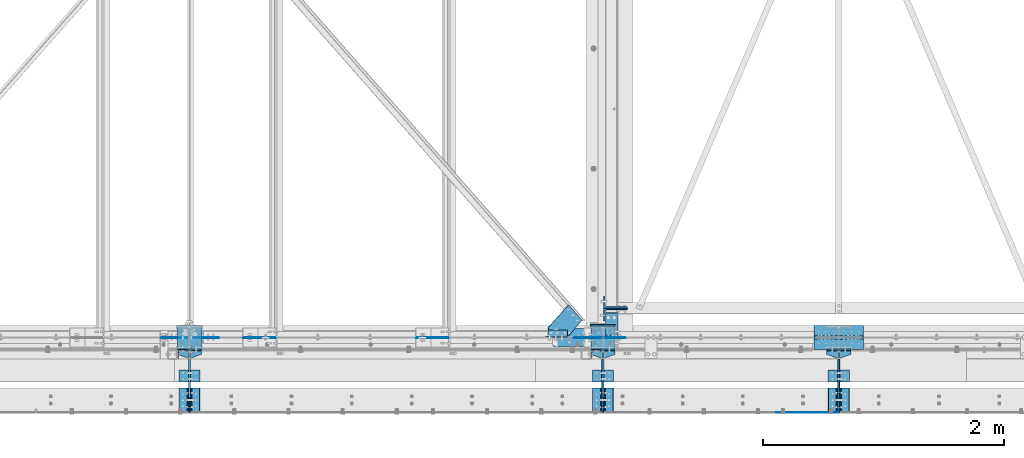
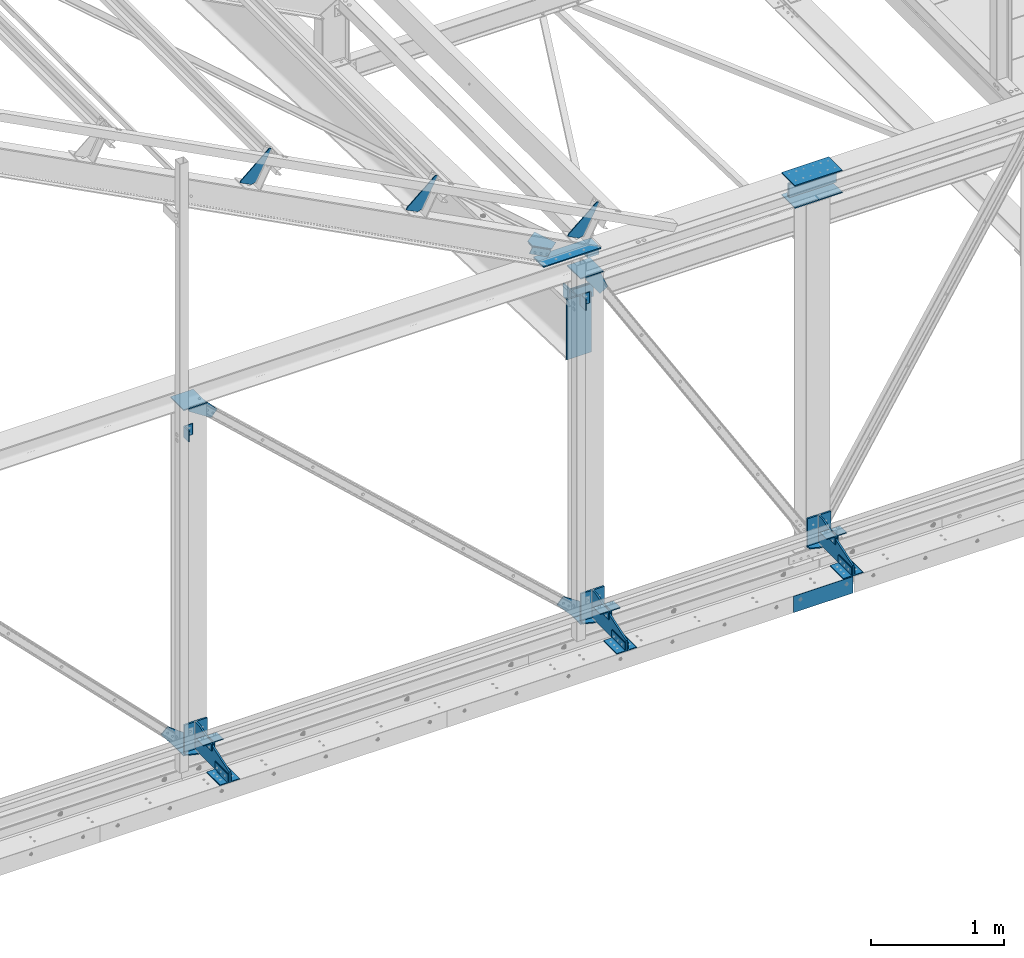
# One storey, part 84 of 496: 43 beams, 3 members, 34 elements without a shape of their own.
"""IFC2X3 building model written with IfcOpenShell, lengths in millimetres."""

from ifc_helpers import new_model, si_unit, frame, origin_with_axes, origin_2d_with_axis, place, context, subcontext, project, spatial, polyline, rectangle, l_section, outline, extrude, clip, halfspace, material, type_object, element, aggregate, save


model = new_model("IFC2X3")

# Units and contexts
model_context = context("Model", 3, precision=1e-05, world=origin_with_axes())
body_context = subcontext(model_context, "Body", "Model", "MODEL_VIEW")
ifc_project = project(units=[si_unit("LENGTHUNIT", "METRE", prefix="MILLI"), si_unit("AREAUNIT", "SQUARE_METRE"), si_unit("VOLUMEUNIT", "CUBIC_METRE"), si_unit("MASSUNIT", "GRAM", prefix="KILO"), si_unit("TIMEUNIT", "SECOND"), si_unit("PLANEANGLEUNIT", "RADIAN"), si_unit("SOLIDANGLEUNIT", "STERADIAN"), si_unit("THERMODYNAMICTEMPERATUREUNIT", "DEGREE_CELSIUS"), si_unit("LUMINOUSINTENSITYUNIT", "LUMEN")], contexts=[model_context])

# Site, building, storey
site_placement = place(None, origin_with_axes())
site = spatial("IfcSite", under=ifc_project, at=site_placement, CompositionType="ELEMENT")
building_placement = place(site_placement, origin_with_axes())
building = spatial("IfcBuilding", under=site, at=building_placement, Name="Undefined", CompositionType="ELEMENT")
storey_placement = place(building_placement, origin_with_axes())
storey = spatial("IfcBuildingStorey", under=building, at=storey_placement, Name="Undefined", CompositionType="ELEMENT", Elevation=0.0)

# Assembly, beam
assembly_1_placement = place(storey_placement, origin_with_axes())
assembly_1 = element("IfcElementAssembly", 1, at=assembly_1_placement, inside=storey, Name="MONTANT", AssemblyPlace="NOTDEFINED", PredefinedType="NOTDEFINED")
ifc_material = material(Name="Undefined/S235-E24")
beam_type_1 = type_object("IfcBeamType", PredefinedType="NOTDEFINED")
beam_1_placement = place(assembly_1_placement, frame((16014.9968916014, 0.0, 5200.00069263517), z_axis=(0.0, -1.0, 0.0), x_axis=(1.0, 0.0, 0.0)))
beam_1 = element("IfcBeam", 2, at=beam_1_placement, type_object=beam_type_1, material=ifc_material, context=body_context, shape_type="SweptSolid", body=[
    extrude(outline(polyline([(0.0, 0.0), (76.7515563964844, -3.31884703335521e-11), (96.7515747071295, 19.9999999994966), (96.7516021728516, 100.0), (-82.7663345336914, 231.440887451172), (-139.650405883789, 175.189651489258), (0.0, 0.0)])), frame((0.0, 0.0, -4.0), z_axis=(0.0, 0.0, 1.0), x_axis=(1.0, 0.0, 0.0)), (0.0, 0.0, 1.0), 8.0),
])

assembly_2_placement = place(storey_placement, origin_with_axes())
assembly_2 = element("IfcElementAssembly", 3, at=assembly_2_placement, inside=storey, Name="SUPPORT", AssemblyPlace="NOTDEFINED", PredefinedType="NOTDEFINED")
beam_type_2 = type_object("IfcBeamType", PredefinedType="NOTDEFINED")
beam_2_placement = place(assembly_2_placement, frame((20989.9999820849, -622.0, 5154.99824538435), z_axis=(0.0, 0.0, 1.0), x_axis=(1.0, 0.0, 0.0)))
beam_2 = element("IfcBeam", 4, at=beam_2_placement, type_object=beam_type_2, material=ifc_material, Name="SUPPORT", context=body_context, shape_type="SweptSolid", body=[
    extrude(rectangle(XDim=4.0, YDim=150.0, at=origin_2d_with_axis()), frame((515.000011943383, 0.0, 0.0), z_axis=(-1.0, 0.0, 0.0), x_axis=(0.0, -1.0, 0.0)), (0.0, 0.0, 1.0), 515.0),
])
aggregate(assembly_2, [beam_2])

assembly_3_placement = place(storey_placement, origin_with_axes())
assembly_3 = element("IfcElementAssembly", 5, at=assembly_3_placement, inside=storey, Name="MONTANT", AssemblyPlace="NOTDEFINED", PredefinedType="NOTDEFINED")
beam_type_3 = type_object("IfcBeamType", PredefinedType="NOTDEFINED")
beam_3_placement = place(assembly_3_placement, frame((21304.9998196885, 0.0, 8354.99960117714), z_axis=(0.0, 1.0, 0.0), x_axis=(0.999999999995014, 0.0, -3.15800000114453e-06)))
beam_3 = element("IfcBeam", 6, at=beam_3_placement, type_object=beam_type_3, material=ifc_material, context=body_context, shape_type="SweptSolid", body=[
    extrude(rectangle(XDim=10.0, YDim=200.0, at=origin_2d_with_axis()), frame((410.0, 0.0, 0.0), z_axis=(-1.0, 0.0, 0.0), x_axis=(0.0, -1.0, 0.0)), (0.0, 0.0, 1.0), 410.0),
])
aggregate(assembly_3, [beam_3])

assembly_4_placement = place(storey_placement, origin_with_axes())
assembly_4 = element("IfcElementAssembly", 7, at=assembly_4_placement, inside=storey, AssemblyPlace="NOTDEFINED", PredefinedType="NOTDEFINED")
beam_4_placement = place(assembly_4_placement, frame((21304.9998196885, 0.0, 8555.00039882286), z_axis=(0.0, 1.0, 0.0), x_axis=(0.999999999995014, 0.0, 3.15800000114453e-06)))
beam_4 = element("IfcBeam", 8, at=beam_4_placement, type_object=beam_type_3, material=ifc_material, context=body_context, shape_type="SweptSolid", body=[
    extrude(rectangle(XDim=10.0, YDim=200.0, at=origin_2d_with_axis()), frame((410.0, 0.0, 0.0), z_axis=(-1.0, 0.0, 0.0), x_axis=(0.0, -1.0, 0.0)), (0.0, 0.0, 1.0), 410.0),
])
aggregate(assembly_4, [beam_4])

# Assembly, beams
assembly_5_placement = place(storey_placement, origin_with_axes())
assembly_5 = element("IfcElementAssembly", 9, at=assembly_5_placement, inside=storey, Name="MONTANT", AssemblyPlace="NOTDEFINED", PredefinedType="NOTDEFINED")
beam_5_placement = place(assembly_5_placement, frame((19449.9982817512, 0.0, 8354.99930736483), z_axis=(0.0, 1.0, 0.0), x_axis=(1.0, 0.0, 0.0)))
beam_5 = element("IfcBeam", 10, at=beam_5_placement, type_object=beam_type_3, material=ifc_material, context=body_context, shape_type="SweptSolid", body=[
    extrude(rectangle(XDim=10.0, YDim=200.0, at=origin_2d_with_axis()), frame((200.003108907451, 1.3235095531086e-21, 0.0), z_axis=(-1.0, 0.0, 0.0), x_axis=(0.0, -1.0, 0.0)), (0.0, 0.0, 1.0), 200.0),
])
beam_6_placement = place(assembly_5_placement, frame((19449.9982812412, 0.0, 5195.00069263517), z_axis=(0.0, 1.0, 0.0), x_axis=(1.0, 0.0, 0.0)))
beam_6 = element("IfcBeam", 11, at=beam_6_placement, type_object=beam_type_3, material=ifc_material, context=body_context, shape_type="SweptSolid", body=[
    extrude(rectangle(XDim=10.0, YDim=200.0, at=origin_2d_with_axis()), frame((200.003108907451, 1.3235095531086e-21, 0.0), z_axis=(-1.0, 0.0, 0.0), x_axis=(0.0, -1.0, 0.0)), (0.0, 0.0, 1.0), 200.0),
])

# Beam
beam_7_placement = place(assembly_1_placement, frame((16014.9968918183, 0.0, 8354.99930736483), z_axis=(0.0, 1.0, 0.0), x_axis=(1.0, 0.0, 0.0)))
beam_7 = element("IfcBeam", 12, at=beam_7_placement, type_object=beam_type_3, material=ifc_material, context=body_context, shape_type="SweptSolid", body=[
    extrude(rectangle(XDim=10.0, YDim=200.0, at=origin_2d_with_axis()), frame((200.003108907451, 1.3235095531086e-21, 0.0), z_axis=(-1.0, 0.0, 0.0), x_axis=(0.0, -1.0, 0.0)), (0.0, 0.0, 1.0), 200.0),
])

beam_8_placement = place(assembly_1_placement, frame((16014.9968913083, 0.0, 5195.00069263517), z_axis=(0.0, 1.0, 0.0), x_axis=(1.0, 0.0, 0.0)))
beam_8 = element("IfcBeam", 13, at=beam_8_placement, type_object=beam_type_3, material=ifc_material, context=body_context, shape_type="SweptSolid", body=[
    extrude(rectangle(XDim=10.0, YDim=200.0, at=origin_2d_with_axis()), frame((200.003108907451, 1.3235095531086e-21, 0.0), z_axis=(-1.0, 0.0, 0.0), x_axis=(0.0, -1.0, 0.0)), (0.0, 0.0, 1.0), 200.0),
])

# Assembly, beam
assembly_6_placement = place(storey_placement, origin_with_axes())
assembly_6 = element("IfcElementAssembly", 14, at=assembly_6_placement, inside=storey, AssemblyPlace="NOTDEFINED", PredefinedType="NOTDEFINED")
beam_type_4 = type_object("IfcBeamType", PredefinedType="NOTDEFINED")
beam_9_placement = place(assembly_6_placement, frame((21557.4921660686, -270.0, 5409.99824538435), z_axis=(0.0, 0.0, -1.0), x_axis=(0.0, -1.0, 0.0)))
beam_9 = element("IfcBeam", 15, at=beam_9_placement, type_object=beam_type_4, material=ifc_material, context=body_context, shape_type="SweptSolid", body=[
    extrude(l_section(Depth=80.0, Width=80.0, Thickness=8.0, FilletRadius=10.0, EdgeRadius=5.0, at=origin_2d_with_axis()), frame((100.000000000021, 5.72981662116945e-11, -4.09272615797818e-12), z_axis=(-1.0, 0.0, 0.0), x_axis=(0.0, -1.0, 0.0)), (0.0, 0.0, 1.0), 100.0),
])
aggregate(assembly_6, [beam_9])

assembly_7_placement = place(storey_placement, origin_with_axes())
assembly_7 = element("IfcElementAssembly", 16, at=assembly_7_placement, inside=storey, AssemblyPlace="NOTDEFINED", PredefinedType="NOTDEFINED")
beam_10_placement = place(assembly_7_placement, frame((21462.4999984401, -370.0, 5409.99824538435), z_axis=(0.0, 0.0, -1.0), x_axis=(0.0, 1.0, 0.0)))
beam_10 = element("IfcBeam", 17, at=beam_10_placement, type_object=beam_type_4, material=ifc_material, context=body_context, shape_type="SweptSolid", body=[
    extrude(l_section(Depth=80.0, Width=80.0, Thickness=8.0, FilletRadius=10.0, EdgeRadius=5.0, at=origin_2d_with_axis()), frame((100.000000000021, 5.72981662116945e-11, -4.09272615797818e-12), z_axis=(-1.0, 0.0, 0.0), x_axis=(0.0, -1.0, 0.0)), (0.0, 0.0, 1.0), 100.0),
])
aggregate(assembly_7, [beam_10])

assembly_8_placement = place(storey_placement, origin_with_axes())
assembly_8 = element("IfcElementAssembly", 18, at=assembly_8_placement, inside=storey, AssemblyPlace="NOTDEFINED", PredefinedType="NOTDEFINED")
beam_11_placement = place(assembly_8_placement, frame((19597.4921676285, -270.0, 5409.99824538435), z_axis=(0.0, 0.0, -1.0), x_axis=(0.0, -1.0, 0.0)))
beam_11 = element("IfcBeam", 19, at=beam_11_placement, type_object=beam_type_4, material=ifc_material, context=body_context, shape_type="SweptSolid", body=[
    extrude(l_section(Depth=80.0, Width=80.0, Thickness=8.0, FilletRadius=10.0, EdgeRadius=5.0, at=origin_2d_with_axis()), frame((100.000000000021, 5.72981662116945e-11, -4.09272615797818e-12), z_axis=(-1.0, 0.0, 0.0), x_axis=(0.0, -1.0, 0.0)), (0.0, 0.0, 1.0), 100.0),
])
aggregate(assembly_8, [beam_11])

assembly_9_placement = place(storey_placement, origin_with_axes())
assembly_9 = element("IfcElementAssembly", 20, at=assembly_9_placement, inside=storey, AssemblyPlace="NOTDEFINED", PredefinedType="NOTDEFINED")
beam_12_placement = place(assembly_9_placement, frame((19502.5, -370.0, 5409.99824538435), z_axis=(0.0, 0.0, -1.0), x_axis=(0.0, 1.0, 0.0)))
beam_12 = element("IfcBeam", 21, at=beam_12_placement, type_object=beam_type_4, material=ifc_material, context=body_context, shape_type="SweptSolid", body=[
    extrude(l_section(Depth=80.0, Width=80.0, Thickness=8.0, FilletRadius=10.0, EdgeRadius=5.0, at=origin_2d_with_axis()), frame((100.000000000021, 5.72981662116945e-11, -4.09272615797818e-12), z_axis=(-1.0, 0.0, 0.0), x_axis=(0.0, -1.0, 0.0)), (0.0, 0.0, 1.0), 100.0),
])
aggregate(assembly_9, [beam_12])

assembly_10_placement = place(storey_placement, origin_with_axes())
assembly_10 = element("IfcElementAssembly", 22, at=assembly_10_placement, inside=storey, AssemblyPlace="NOTDEFINED", PredefinedType="NOTDEFINED")
beam_13_placement = place(assembly_10_placement, frame((16162.490751722, -270.0, 5409.99824538435), z_axis=(0.0, 0.0, -1.0), x_axis=(0.0, -1.0, 0.0)))
beam_13 = element("IfcBeam", 23, at=beam_13_placement, type_object=beam_type_4, material=ifc_material, context=body_context, shape_type="SweptSolid", body=[
    extrude(l_section(Depth=80.0, Width=80.0, Thickness=8.0, FilletRadius=10.0, EdgeRadius=5.0, at=origin_2d_with_axis()), frame((100.000000000021, 5.72981662116945e-11, -4.09272615797818e-12), z_axis=(-1.0, 0.0, 0.0), x_axis=(0.0, -1.0, 0.0)), (0.0, 0.0, 1.0), 100.0),
])
aggregate(assembly_10, [beam_13])

assembly_11_placement = place(storey_placement, origin_with_axes())
assembly_11 = element("IfcElementAssembly", 24, at=assembly_11_placement, inside=storey, AssemblyPlace="NOTDEFINED", PredefinedType="NOTDEFINED")
beam_14_placement = place(assembly_11_placement, frame((16067.4985840935, -370.0, 5409.99824538435), z_axis=(0.0, 0.0, -1.0), x_axis=(0.0, 1.0, 0.0)))
beam_14 = element("IfcBeam", 25, at=beam_14_placement, type_object=beam_type_4, material=ifc_material, context=body_context, shape_type="SweptSolid", body=[
    extrude(l_section(Depth=80.0, Width=80.0, Thickness=8.0, FilletRadius=10.0, EdgeRadius=5.0, at=origin_2d_with_axis()), frame((100.000000000021, 5.72981662116945e-11, -4.09272615797818e-12), z_axis=(-1.0, 0.0, 0.0), x_axis=(0.0, -1.0, 0.0)), (0.0, 0.0, 1.0), 100.0),
])
aggregate(assembly_11, [beam_14])

assembly_12_placement = place(storey_placement, origin_with_axes())
assembly_12 = element("IfcElementAssembly", 26, at=assembly_12_placement, inside=storey, AssemblyPlace="NOTDEFINED", PredefinedType="NOTDEFINED")
beam_15_placement = place(assembly_12_placement, frame((21557.4921660686, -620.0, 5269.99824538435), z_axis=(0.0, 0.0, 1.0), x_axis=(0.0, 1.0, 0.0)))
beam_15 = element("IfcBeam", 27, at=beam_15_placement, type_object=beam_type_4, material=ifc_material, context=body_context, shape_type="SweptSolid", body=[
    extrude(l_section(Depth=80.0, Width=80.0, Thickness=8.0, FilletRadius=10.0, EdgeRadius=5.0, at=origin_2d_with_axis()), frame((200.0, 0.0, 0.0), z_axis=(-1.0, 0.0, 0.0), x_axis=(0.0, -1.0, 0.0)), (0.0, 0.0, 1.0), 200.0),
])
aggregate(assembly_12, [beam_15])

assembly_13_placement = place(storey_placement, origin_with_axes())
assembly_13 = element("IfcElementAssembly", 28, at=assembly_13_placement, inside=storey, AssemblyPlace="NOTDEFINED", PredefinedType="NOTDEFINED")
beam_16_placement = place(assembly_13_placement, frame((21462.4999984401, -420.0, 5269.99824538435), z_axis=(0.0, 0.0, 1.0), x_axis=(0.0, -1.0, 0.0)))
beam_16 = element("IfcBeam", 29, at=beam_16_placement, type_object=beam_type_4, material=ifc_material, context=body_context, shape_type="SweptSolid", body=[
    extrude(l_section(Depth=80.0, Width=80.0, Thickness=8.0, FilletRadius=10.0, EdgeRadius=5.0, at=origin_2d_with_axis()), frame((200.0, 0.0, 0.0), z_axis=(-1.0, 0.0, 0.0), x_axis=(0.0, -1.0, 0.0)), (0.0, 0.0, 1.0), 200.0),
])
aggregate(assembly_13, [beam_16])

assembly_14_placement = place(storey_placement, origin_with_axes())
assembly_14 = element("IfcElementAssembly", 30, at=assembly_14_placement, inside=storey, AssemblyPlace="NOTDEFINED", PredefinedType="NOTDEFINED")
beam_17_placement = place(assembly_14_placement, frame((19597.4921676285, -620.0, 5269.99824538435), z_axis=(0.0, 0.0, 1.0), x_axis=(0.0, 1.0, 0.0)))
beam_17 = element("IfcBeam", 31, at=beam_17_placement, type_object=beam_type_4, material=ifc_material, context=body_context, shape_type="SweptSolid", body=[
    extrude(l_section(Depth=80.0, Width=80.0, Thickness=8.0, FilletRadius=10.0, EdgeRadius=5.0, at=origin_2d_with_axis()), frame((200.0, 0.0, 0.0), z_axis=(-1.0, 0.0, 0.0), x_axis=(0.0, -1.0, 0.0)), (0.0, 0.0, 1.0), 200.0),
])
aggregate(assembly_14, [beam_17])

assembly_15_placement = place(storey_placement, origin_with_axes())
assembly_15 = element("IfcElementAssembly", 32, at=assembly_15_placement, inside=storey, AssemblyPlace="NOTDEFINED", PredefinedType="NOTDEFINED")
beam_18_placement = place(assembly_15_placement, frame((19502.5, -420.0, 5269.99824538435), z_axis=(0.0, 0.0, 1.0), x_axis=(0.0, -1.0, 0.0)))
beam_18 = element("IfcBeam", 33, at=beam_18_placement, type_object=beam_type_4, material=ifc_material, context=body_context, shape_type="SweptSolid", body=[
    extrude(l_section(Depth=80.0, Width=80.0, Thickness=8.0, FilletRadius=10.0, EdgeRadius=5.0, at=origin_2d_with_axis()), frame((200.0, 0.0, 0.0), z_axis=(-1.0, 0.0, 0.0), x_axis=(0.0, -1.0, 0.0)), (0.0, 0.0, 1.0), 200.0),
])
aggregate(assembly_15, [beam_18])

assembly_16_placement = place(storey_placement, origin_with_axes())
assembly_16 = element("IfcElementAssembly", 34, at=assembly_16_placement, inside=storey, AssemblyPlace="NOTDEFINED", PredefinedType="NOTDEFINED")
beam_19_placement = place(assembly_16_placement, frame((16162.490751722, -620.0, 5269.99824538435), z_axis=(0.0, 0.0, 1.0), x_axis=(0.0, 1.0, 0.0)))
beam_19 = element("IfcBeam", 35, at=beam_19_placement, type_object=beam_type_4, material=ifc_material, context=body_context, shape_type="SweptSolid", body=[
    extrude(l_section(Depth=80.0, Width=80.0, Thickness=8.0, FilletRadius=10.0, EdgeRadius=5.0, at=origin_2d_with_axis()), frame((200.0, 0.0, 0.0), z_axis=(-1.0, 0.0, 0.0), x_axis=(0.0, -1.0, 0.0)), (0.0, 0.0, 1.0), 200.0),
])
aggregate(assembly_16, [beam_19])

assembly_17_placement = place(storey_placement, origin_with_axes())
assembly_17 = element("IfcElementAssembly", 36, at=assembly_17_placement, inside=storey, AssemblyPlace="NOTDEFINED", PredefinedType="NOTDEFINED")
beam_20_placement = place(assembly_17_placement, frame((16067.4985840935, -420.0, 5269.99824538435), z_axis=(0.0, 0.0, 1.0), x_axis=(0.0, -1.0, 0.0)))
beam_20 = element("IfcBeam", 37, at=beam_20_placement, type_object=beam_type_4, material=ifc_material, context=body_context, shape_type="SweptSolid", body=[
    extrude(l_section(Depth=80.0, Width=80.0, Thickness=8.0, FilletRadius=10.0, EdgeRadius=5.0, at=origin_2d_with_axis()), frame((200.0, 0.0, 0.0), z_axis=(-1.0, 0.0, 0.0), x_axis=(0.0, -1.0, 0.0)), (0.0, 0.0, 1.0), 200.0),
])
aggregate(assembly_17, [beam_20])

assembly_18_placement = place(storey_placement, origin_with_axes())
assembly_18 = element("IfcElementAssembly", 38, at=assembly_18_placement, inside=storey, AssemblyPlace="NOTDEFINED", PredefinedType="NOTDEFINED")
beam_21_placement = place(assembly_18_placement, frame((19489.9999999948, -134.999999998163, 8210.00066229852), z_axis=(1.0, 0.0, 0.0), x_axis=(0.0, 0.0, -1.0)))
beam_21 = element("IfcBeam", 39, at=beam_21_placement, type_object=beam_type_4, material=ifc_material, context=body_context, shape_type="SweptSolid", body=[
    extrude(l_section(Depth=80.0, Width=80.0, Thickness=8.0, FilletRadius=10.0, EdgeRadius=5.0, at=origin_2d_with_axis()), frame((100.000000000021, 5.72981662116945e-11, -4.09272615797818e-12), z_axis=(-1.0, 0.0, 0.0), x_axis=(0.0, -1.0, 0.0)), (0.0, 0.0, 1.0), 100.0),
])
aggregate(assembly_18, [beam_21])

assembly_19_placement = place(storey_placement, origin_with_axes())
assembly_19 = element("IfcElementAssembly", 40, at=assembly_19_placement, inside=storey, AssemblyPlace="NOTDEFINED", PredefinedType="NOTDEFINED")
beam_22_placement = place(assembly_19_placement, frame((16054.9998811591, -135.000000001492, 8210.00066228986), z_axis=(1.0, 0.0, 0.0), x_axis=(0.0, 0.0, -1.0)))
beam_22 = element("IfcBeam", 41, at=beam_22_placement, type_object=beam_type_4, material=ifc_material, context=body_context, shape_type="SweptSolid", body=[
    extrude(l_section(Depth=80.0, Width=80.0, Thickness=8.0, FilletRadius=10.0, EdgeRadius=5.0, at=origin_2d_with_axis()), frame((100.000000000021, 5.72981662116945e-11, -4.09272615797818e-12), z_axis=(-1.0, 0.0, 0.0), x_axis=(0.0, -1.0, 0.0)), (0.0, 0.0, 1.0), 100.0),
])
aggregate(assembly_19, [beam_22])

assembly_20_placement = place(storey_placement, origin_with_axes())
assembly_20 = element("IfcElementAssembly", 42, at=assembly_20_placement, inside=storey, Name="CONSOLE", AssemblyPlace="NOTDEFINED", PredefinedType="NOTDEFINED")
beam_type_5 = type_object("IfcBeamType", PredefinedType="NOTDEFINED")
beam_23_placement = place(assembly_20_placement, frame((16014.9985840935, -110.0, 5224.99824534403), z_axis=(0.0, 0.0, 1.0), x_axis=(0.0, -1.0, 0.0)))
beam_23 = element("IfcBeam", 43, at=beam_23_placement, type_object=beam_type_5, material=ifc_material, context=body_context, shape_type="SweptSolid", body=[
    extrude(outline(polyline([(0.0, 0.0), (30.0, 0.0), (60.0, 82.5), (60.0, 117.5), (30.0, 200.0), (0.0, 200.0), (0.0, 0.0)])), frame((0.0, 0.0, -5.0), z_axis=(0.0, 0.0, 1.0), x_axis=(1.0, 0.0, 0.0)), (0.0, 0.0, 1.0), 10.0),
])

assembly_21_placement = place(storey_placement, origin_with_axes())
assembly_21 = element("IfcElementAssembly", 44, at=assembly_21_placement, inside=storey, Name="CONSOLE", AssemblyPlace="NOTDEFINED", PredefinedType="NOTDEFINED")
beam_24_placement = place(assembly_21_placement, frame((19450.0, -110.0, 5224.99824534403), z_axis=(0.0, 0.0, 1.0), x_axis=(0.0, -1.0, 0.0)))
beam_24 = element("IfcBeam", 45, at=beam_24_placement, type_object=beam_type_5, material=ifc_material, context=body_context, shape_type="SweptSolid", body=[
    extrude(outline(polyline([(0.0, 0.0), (30.0, 0.0), (60.0, 82.5), (60.0, 117.5), (30.0, 200.0), (0.0, 200.0), (0.0, 0.0)])), frame((0.0, 0.0, -5.0), z_axis=(0.0, 0.0, 1.0), x_axis=(1.0, 0.0, 0.0)), (0.0, 0.0, 1.0), 10.0),
])

# Assembly, beams
assembly_22_placement = place(storey_placement, origin_with_axes())
assembly_22 = element("IfcElementAssembly", 46, at=assembly_22_placement, inside=storey, Name="CONSOLE", AssemblyPlace="NOTDEFINED", PredefinedType="NOTDEFINED")
beam_25_placement = place(assembly_22_placement, frame((21409.9999984401, -110.0, 5224.99824534403), z_axis=(0.0, 0.0, 1.0), x_axis=(0.0, -1.0, 0.0)))
beam_25 = element("IfcBeam", 47, at=beam_25_placement, type_object=beam_type_5, material=ifc_material, context=body_context, shape_type="SweptSolid", body=[
    extrude(outline(polyline([(0.0, 0.0), (30.0, 0.0), (60.0, 82.5), (60.0, 117.5), (30.0, 200.0), (0.0, 200.0), (0.0, 0.0)])), frame((0.0, 0.0, -5.0), z_axis=(0.0, 0.0, 1.0), x_axis=(1.0, 0.0, 0.0)), (0.0, 0.0, 1.0), 10.0),
])
beam_type_6 = type_object("IfcBeamType", PredefinedType="NOTDEFINED")
beam_26_placement = place(assembly_22_placement, frame((21509.9999984401, -102.5, 5479.99824538435), z_axis=(1.0, 0.0, 0.0), x_axis=(0.0, 0.0, -1.0)))
beam_26 = element("IfcBeam", 48, at=beam_26_placement, type_object=beam_type_6, material=ifc_material, context=body_context, shape_type="SweptSolid", body=[
    extrude(rectangle(XDim=15.0, YDim=200.0, at=origin_2d_with_axis()), frame((265.000000057562, 0.0, 0.0), z_axis=(-1.0, 0.0, 0.0), x_axis=(0.0, -1.0, 0.0)), (0.0, 0.0, 1.0), 265.0),
])

# Beam
beam_27_placement = place(assembly_21_placement, frame((19550.0, -102.5, 5479.99824538435), z_axis=(1.0, 0.0, 0.0), x_axis=(0.0, 0.0, -1.0)))
beam_27 = element("IfcBeam", 49, at=beam_27_placement, type_object=beam_type_6, material=ifc_material, context=body_context, shape_type="SweptSolid", body=[
    extrude(rectangle(XDim=15.0, YDim=200.0, at=origin_2d_with_axis()), frame((265.000000057562, 0.0, 0.0), z_axis=(-1.0, 0.0, 0.0), x_axis=(0.0, -1.0, 0.0)), (0.0, 0.0, 1.0), 265.0),
])

beam_28_placement = place(assembly_20_placement, frame((16114.9985840935, -102.5, 5479.99824538435), z_axis=(1.0, 0.0, 0.0), x_axis=(0.0, 0.0, -1.0)))
beam_28 = element("IfcBeam", 50, at=beam_28_placement, type_object=beam_type_6, material=ifc_material, context=body_context, shape_type="SweptSolid", body=[
    extrude(rectangle(XDim=15.0, YDim=200.0, at=origin_2d_with_axis()), frame((265.000000057562, 0.0, 0.0), z_axis=(-1.0, 0.0, 0.0), x_axis=(0.0, -1.0, 0.0)), (0.0, 0.0, 1.0), 265.0),
])

beam_type_7 = type_object("IfcBeamType", PredefinedType="NOTDEFINED")
beam_29_placement = place(assembly_22_placement, frame((21509.9999984401, -620.0, 5229.99824538435), z_axis=(-1.0, 0.0, 0.0), x_axis=(0.0, 0.0, 1.0)))
beam_29 = element("IfcBeam", 51, at=beam_29_placement, type_object=beam_type_7, material=ifc_material, Name="CONSOLE", context=body_context, shape_type="SweptSolid", body=[
    extrude(outline(polyline([(0.0, 0.0), (100.0, 0.0), (250.0, 450.0), (250.0, 510.0), (19.9999999424381, 510.0), (-5.53045894918671e-08, 490.0), (0.0, 0.0)])), frame((0.0, 0.0, -7.5), z_axis=(0.0, 0.0, 1.0), x_axis=(1.0, 0.0, 0.0)), (0.0, 0.0, 1.0), 15.0),
])

aggregate(assembly_22, [beam_25, beam_26, beam_29])

beam_30_placement = place(assembly_21_placement, frame((19550.0, -620.0, 5229.99824538435), z_axis=(-1.0, 0.0, 0.0), x_axis=(0.0, 0.0, 1.0)))
beam_30 = element("IfcBeam", 52, at=beam_30_placement, type_object=beam_type_7, material=ifc_material, Name="CONSOLE", context=body_context, shape_type="SweptSolid", body=[
    extrude(outline(polyline([(0.0, 0.0), (100.0, 0.0), (250.0, 450.0), (250.0, 510.0), (19.9999999424381, 510.0), (-5.53045894918671e-08, 490.0), (0.0, 0.0)])), frame((0.0, 0.0, -7.5), z_axis=(0.0, 0.0, 1.0), x_axis=(1.0, 0.0, 0.0)), (0.0, 0.0, 1.0), 15.0),
])

aggregate(assembly_21, [beam_24, beam_27, beam_30])

beam_31_placement = place(assembly_20_placement, frame((16114.9985840935, -620.0, 5229.99824538435), z_axis=(-1.0, 0.0, 0.0), x_axis=(0.0, 0.0, 1.0)))
beam_31 = element("IfcBeam", 53, at=beam_31_placement, type_object=beam_type_7, material=ifc_material, Name="CONSOLE", context=body_context, shape_type="SweptSolid", body=[
    extrude(outline(polyline([(0.0, 0.0), (100.0, 0.0), (250.0, 450.0), (250.0, 510.0), (19.9999999424381, 510.0), (-5.53045894918671e-08, 490.0), (0.0, 0.0)])), frame((0.0, 0.0, -7.5), z_axis=(0.0, 0.0, 1.0), x_axis=(1.0, 0.0, 0.0)), (0.0, 0.0, 1.0), 15.0),
])

aggregate(assembly_20, [beam_23, beam_28, beam_31])

# Assembly, member
assembly_23_placement = place(storey_placement, origin_with_axes())
assembly_23 = element("IfcElementAssembly", 54, at=assembly_23_placement, inside=storey, AssemblyPlace="NOTDEFINED", PredefinedType="NOTDEFINED")
member_type_1 = type_object("IfcMemberType", PredefinedType="NOTDEFINED")
member_1_placement = place(assembly_23_placement, frame((19240.9060810752, 33.499997216567, 8598.41231176399), z_axis=(0.0, 1.0, 0.0), x_axis=(-0.886081824994261, -1.3000000762986e-08, 0.46352885499701)))
member_1 = element("IfcMember", 55, at=member_1_placement, type_object=member_type_1, material=ifc_material, context=body_context, shape_type="SweptSolid", body=[
    extrude(l_section(Depth=60.0, Width=60.0, Thickness=6.0, FilletRadius=8.0, EdgeRadius=4.0, at=origin_2d_with_axis()), frame((180.0, 0.0, 0.0), z_axis=(-1.0, 0.0, 0.0), x_axis=(0.0, -1.0, 0.0)), (0.0, 0.0, 1.0), 180.0),
])
aggregate(assembly_23, [member_1])

# Assembly, beam
assembly_24_placement = place(storey_placement, origin_with_axes())
assembly_24 = element("IfcElementAssembly", 56, at=assembly_24_placement, inside=storey, Name="SHED", AssemblyPlace="NOTDEFINED", PredefinedType="NOTDEFINED")
beam_type_8 = type_object("IfcBeamType", PredefinedType="NOTDEFINED")
beam_32_placement = place(assembly_24_placement, frame((19667.0878027865, 0.0, 8923.94974997789), z_axis=(0.0, -1.0, 0.0), x_axis=(-0.886081824994261, -1.3000000762986e-08, 0.46352885499701)))
beam_32 = element("IfcBeam", 57, at=beam_32_placement, type_object=beam_type_8, material=ifc_material, context=body_context, shape_type="SweptSolid", body=[
    extrude(outline(polyline([(0.0, 0.0), (20.0, 0.0), (140.000030519084, 299.999999999567), (140.000030519153, 319.999999999545), (30.0000147075953, 319.999999999634), (0.0, 290.0), (0.0, 0.0)])), frame((0.0, 0.0, -4.0), z_axis=(0.0, 0.0, 1.0), x_axis=(1.0, 0.0, 0.0)), (0.0, 0.0, 1.0), 8.0),
])
aggregate(assembly_24, [beam_32])

assembly_25_placement = place(storey_placement, origin_with_axes())
assembly_25 = element("IfcElementAssembly", 58, at=assembly_25_placement, inside=storey, Name="SHED", AssemblyPlace="NOTDEFINED", PredefinedType="NOTDEFINED")
beam_33_placement = place(assembly_25_placement, frame((18269.6614730661, 0.0, 9654.97325100623), z_axis=(0.0, -1.0, 0.0), x_axis=(-0.886081824994261, -1.3000000762986e-08, 0.46352885499701)))
beam_33 = element("IfcBeam", 59, at=beam_33_placement, type_object=beam_type_8, material=ifc_material, context=body_context, shape_type="SweptSolid", body=[
    extrude(outline(polyline([(0.0, 0.0), (20.0, 0.0), (140.000030519084, 299.999999999567), (140.000030519153, 319.999999999545), (30.0000147075953, 319.999999999634), (0.0, 290.0), (0.0, 0.0)])), frame((0.0, 0.0, -4.0), z_axis=(0.0, 0.0, 1.0), x_axis=(1.0, 0.0, 0.0)), (0.0, 0.0, 1.0), 8.0),
])
aggregate(assembly_25, [beam_33])

assembly_26_placement = place(storey_placement, origin_with_axes())
assembly_26 = element("IfcElementAssembly", 60, at=assembly_26_placement, inside=storey, Name="SHED", AssemblyPlace="NOTDEFINED", PredefinedType="NOTDEFINED")
beam_34_placement = place(assembly_26_placement, frame((16832.361407792, 0.0, 10406.855553063), z_axis=(0.0, -1.0, 0.0), x_axis=(-0.886081824994261, -1.3000000762986e-08, 0.46352885499701)))
beam_34 = element("IfcBeam", 61, at=beam_34_placement, type_object=beam_type_8, material=ifc_material, context=body_context, shape_type="SweptSolid", body=[
    extrude(outline(polyline([(0.0, 0.0), (20.0, 0.0), (140.000030519084, 299.999999999567), (140.000030519153, 319.999999999545), (30.0000147075953, 319.999999999634), (0.0, 290.0), (0.0, 0.0)])), frame((0.0, 0.0, -4.0), z_axis=(0.0, 0.0, 1.0), x_axis=(1.0, 0.0, 0.0)), (0.0, 0.0, 1.0), 8.0),
])
aggregate(assembly_26, [beam_34])

# Assembly, member
assembly_27_placement = place(storey_placement, origin_with_axes())
assembly_27 = element("IfcElementAssembly", 62, at=assembly_27_placement, inside=storey, AssemblyPlace="NOTDEFINED", PredefinedType="NOTDEFINED")
member_type_2 = type_object("IfcMemberType", PredefinedType="NOTDEFINED")
member_2_placement = place(assembly_27_placement, frame((19656.0000000001, 293.26862890577, 7890.70974897597), z_axis=(1.0, 0.0, 0.0), x_axis=(0.0, 0.031410887010906, 0.999506556345274)))
member_2 = element("IfcMember", 63, at=member_2_placement, type_object=member_type_2, material=ifc_material, context=body_context, shape_type="SweptSolid", body=[
    extrude(l_section(Depth=200.0, Width=100.0, Thickness=10.0, FilletRadius=15.0, EdgeRadius=7.5, at=origin_2d_with_axis()), frame((120.0, 0.0, 0.0), z_axis=(-1.0, 0.0, 0.0), x_axis=(0.0, -1.0, 0.0)), (0.0, 0.0, 1.0), 120.0),
])
aggregate(assembly_27, [member_2])

assembly_28_placement = place(storey_placement, origin_with_axes())
assembly_28 = element("IfcElementAssembly", 64, at=assembly_28_placement, inside=storey, AssemblyPlace="NOTDEFINED", PredefinedType="NOTDEFINED")
member_3_placement = place(assembly_28_placement, frame((19656.0000000001, 191.089419338971, 8013.98015068422), z_axis=(1.0, 0.0, 0.0), x_axis=(0.0, -0.031410887010906, -0.999506556345274)))
member_3 = element("IfcMember", 65, at=member_3_placement, type_object=member_type_2, material=ifc_material, context=body_context, shape_type="SweptSolid", body=[
    extrude(l_section(Depth=200.0, Width=100.0, Thickness=10.0, FilletRadius=15.0, EdgeRadius=7.5, at=origin_2d_with_axis()), frame((120.0, 0.0, 0.0), z_axis=(-1.0, 0.0, 0.0), x_axis=(0.0, -1.0, 0.0)), (0.0, 0.0, 1.0), 120.0),
])
aggregate(assembly_28, [member_3])

# Assembly, beam
assembly_29_placement = place(storey_placement, origin_with_axes())
assembly_29 = element("IfcElementAssembly", 66, at=assembly_29_placement, inside=storey, AssemblyPlace="NOTDEFINED", PredefinedType="NOTDEFINED")
beam_type_9 = type_object("IfcBeamType", PredefinedType="NOTDEFINED")
beam_35_placement = place(assembly_29_placement, frame((19569.9999986305, 106.0, 8490.0), z_axis=(0.0, 1.0, 0.0), x_axis=(1.0, 0.0, 0.0)))
beam_35 = element("IfcBeam", 67, at=beam_35_placement, type_object=beam_type_9, material=ifc_material, context=body_context, shape_type="Clipping", body=[
    clip(extrude(l_section(Depth=200.0, Width=100.0, Thickness=10.0, FilletRadius=15.0, EdgeRadius=7.5, at=origin_2d_with_axis()), frame((100.000000000021, 5.72981662116945e-11, -4.09272615797818e-12), z_axis=(-1.0, 0.0, 0.0), x_axis=(0.0, -1.0, 0.0)), (0.0, 0.0, 1.0), 100.0), halfspace(frame((100.0, -20.0, -100.0), z_axis=(0.0, -1.0, 0.0), x_axis=(-1.0, 0.0, 0.0)), False)),
])
aggregate(assembly_29, [beam_35])

assembly_30_placement = place(storey_placement, origin_with_axes())
assembly_30 = element("IfcElementAssembly", 68, at=assembly_30_placement, inside=storey, Name="TRAVERSE", AssemblyPlace="NOTDEFINED", PredefinedType="NOTDEFINED")
beam_type_10 = type_object("IfcBeamType", PredefinedType="NOTDEFINED")
beam_36_placement = place(assembly_30_placement, frame((19550.0, 102.5, 8046.54311074126), z_axis=(-1.0, 0.0, 0.0), x_axis=(0.0, 0.0, -1.0)))
beam_36 = element("IfcBeam", 69, at=beam_36_placement, type_object=beam_type_10, material=ifc_material, context=body_context, shape_type="SweptSolid", body=[
    extrude(rectangle(XDim=15.0, YDim=210.0, at=origin_2d_with_axis()), frame((550.00003132, 0.0, 0.0), z_axis=(-1.0, 0.0, 0.0), x_axis=(0.0, -1.0, 0.0)), (0.0, 0.0, 1.0), 550.0),
])
aggregate(assembly_30, [beam_36])

assembly_31_placement = place(storey_placement, origin_with_axes())
assembly_31 = element("IfcElementAssembly", 70, at=assembly_31_placement, inside=storey, AssemblyPlace="NOTDEFINED", PredefinedType="NOTDEFINED")
beam_type_11 = type_object("IfcBeamType", PredefinedType="NOTDEFINED")
beam_37_placement = place(assembly_31_placement, frame((19376.5667187273, 144.384161047778, 8564.68797075148), z_axis=(0.46352885499701, 6.99999093634976e-09, 0.886081824994261), x_axis=(-0.624617921816656, 0.709285727791797, 0.326750987904095)))
beam_37 = element("IfcBeam", 71, at=beam_37_placement, type_object=beam_type_11, material=ifc_material, context=body_context, shape_type="SweptSolid", body=[
    extrude(outline(polyline([(0.0, 0.0), (180.000000001455, -5.27506927028298e-10), (180.000000001763, 266.398742674894), (129.807098390535, 316.28277587812), (-4.12791108908095, 181.518493652149), (0.0, 0.0)])), frame((0.0, 0.0, -3.0), z_axis=(0.0, 0.0, 1.0), x_axis=(1.0, 0.0, 0.0)), (0.0, 0.0, 1.0), 6.0),
])
aggregate(assembly_31, [beam_37])

assembly_32_placement = place(storey_placement, origin_with_axes())
assembly_32 = element("IfcElementAssembly", 72, at=assembly_32_placement, inside=storey, Name="TRAVERSE SHED", AssemblyPlace="NOTDEFINED", PredefinedType="NOTDEFINED")
beam_type_12 = type_object("IfcBeamType", PredefinedType="NOTDEFINED")
beam_38_placement = place(assembly_32_placement, frame((19391.9989824198, 74.9996843547831, 8554.99999999947), z_axis=(-1.0, 0.0, 0.0), x_axis=(0.0, -1.0, 0.0)))
beam_38 = element("IfcBeam", 73, at=beam_38_placement, type_object=beam_type_12, material=ifc_material, context=body_context, shape_type="SweptSolid", body=[
    extrude(rectangle(XDim=10.0, YDim=500.0, at=origin_2d_with_axis()), frame((149.999995982835, 4.54747350886464e-12, 3.63797880709171e-12), z_axis=(-1.0, 0.0, 0.0), x_axis=(0.0, -1.0, 0.0)), (0.0, 0.0, 1.0), 150.0),
])
aggregate(assembly_32, [beam_38])

assembly_33_placement = place(storey_placement, origin_with_axes())
assembly_33 = element("IfcElementAssembly", 74, at=assembly_33_placement, inside=storey, AssemblyPlace="NOTDEFINED", PredefinedType="NOTDEFINED")
beam_type_13 = type_object("IfcBeamType", PredefinedType="NOTDEFINED")
beam_39_placement = place(assembly_33_placement, frame((21304.9998354776, 8.5, 8455.0), z_axis=(0.0, 0.0, -1.0), x_axis=(1.0, 0.0, 0.0)))
beam_39 = element("IfcBeam", 75, at=beam_39_placement, type_object=beam_type_13, material=ifc_material, context=body_context, shape_type="SweptSolid", body=[
    extrude(rectangle(XDim=10.0, YDim=120.0, at=origin_2d_with_axis()), frame((410.0, 0.0, 0.0), z_axis=(-1.0, 0.0, 0.0), x_axis=(0.0, -1.0, 0.0)), (0.0, 0.0, 1.0), 410.0),
])
aggregate(assembly_33, [beam_39])

assembly_34_placement = place(storey_placement, origin_with_axes())
assembly_34 = element("IfcElementAssembly", 76, at=assembly_34_placement, inside=storey, AssemblyPlace="NOTDEFINED", PredefinedType="NOTDEFINED")
beam_40_placement = place(assembly_34_placement, frame((21304.9998354776, -8.5, 8455.0), z_axis=(0.0, 0.0, -1.0), x_axis=(1.0, 0.0, 0.0)))
beam_40 = element("IfcBeam", 77, at=beam_40_placement, type_object=beam_type_13, material=ifc_material, context=body_context, shape_type="SweptSolid", body=[
    extrude(rectangle(XDim=10.0, YDim=120.0, at=origin_2d_with_axis()), frame((410.0, 0.0, 0.0), z_axis=(-1.0, 0.0, 0.0), x_axis=(0.0, -1.0, 0.0)), (0.0, 0.0, 1.0), 410.0),
])
aggregate(assembly_34, [beam_40])

# Beam
beam_type_14 = type_object("IfcBeamType", PredefinedType="NOTDEFINED")
beam_41_placement = place(assembly_5_placement, frame((19553.25, 0.0, 8250.0), z_axis=(0.0, 1.0, 0.0), x_axis=(0.0, 0.0, 1.0)))
beam_41 = element("IfcBeam", 78, at=beam_41_placement, type_object=beam_type_14, material=ifc_material, context=body_context, shape_type="SweptSolid", body=[
    extrude(outline(polyline([(0.0, 0.0), (80.00000000008, 8.00355337560177e-11), (99.9998580598133, 19.9999999994963), (99.9993133544922, 96.7513885498047), (-124.130233764648, 188.539886474609), (-166.201644897461, 120.495819091797), (0.0, 0.0)])), frame((0.0, 0.0, -4.0), z_axis=(0.0, 0.0, 1.0), x_axis=(1.0, 0.0, 0.0)), (0.0, 0.0, 1.0), 8.0),
])

beam_type_15 = type_object("IfcBeamType", PredefinedType="NOTDEFINED")
beam_42_placement = place(assembly_5_placement, frame((19449.9982815342, 0.0, 5200.00069263517), z_axis=(0.0, -1.0, 0.0), x_axis=(0.999999999974374, 0.0, -7.15899999975953e-06)))
beam_42 = element("IfcBeam", 79, at=beam_42_placement, type_object=beam_type_15, material=ifc_material, context=body_context, shape_type="SweptSolid", body=[
    extrude(outline(polyline([(0.0, 0.0), (76.7517166138678, 0.0), (96.7515747071295, 19.9999999994966), (96.7510070801764, 100.000000000093), (-93.3379211426764, 222.852066040252), (-147.592788696431, 164.06083679215), (0.0, 0.0)])), frame((0.0, 0.0, -4.0), z_axis=(0.0, 0.0, 1.0), x_axis=(1.0, 0.0, 0.0)), (0.0, 0.0, 1.0), 8.0),
])

aggregate(assembly_5, [beam_41, beam_42, beam_5, beam_6])

beam_43_placement = place(assembly_1_placement, frame((16215.0000010188, 0.0, 8349.99931603499), z_axis=(0.0, -1.0, 0.0), x_axis=(-0.999999998732439, 0.0, -5.03499999791828e-05)))
beam_43 = element("IfcBeam", 80, at=beam_43_placement, type_object=beam_type_15, material=ifc_material, context=body_context, shape_type="SweptSolid", body=[
    extrude(outline(polyline([(0.0, 0.0), (76.7499999998417, -5.05039822767232e-11), (96.7510177610709, 19.9999999740404), (96.7550888059941, 99.9999999998308), (-93.3266601560917, 222.857437133421), (-147.584915160887, 164.069335937227), (0.0, 0.0)])), frame((0.0, 0.0, -4.0), z_axis=(0.0, 0.0, 1.0), x_axis=(1.0, 0.0, 0.0)), (0.0, 0.0, 1.0), 8.0),
])

aggregate(assembly_1, [beam_43, beam_1, beam_7, beam_8])

save(model, "model.ifc")
